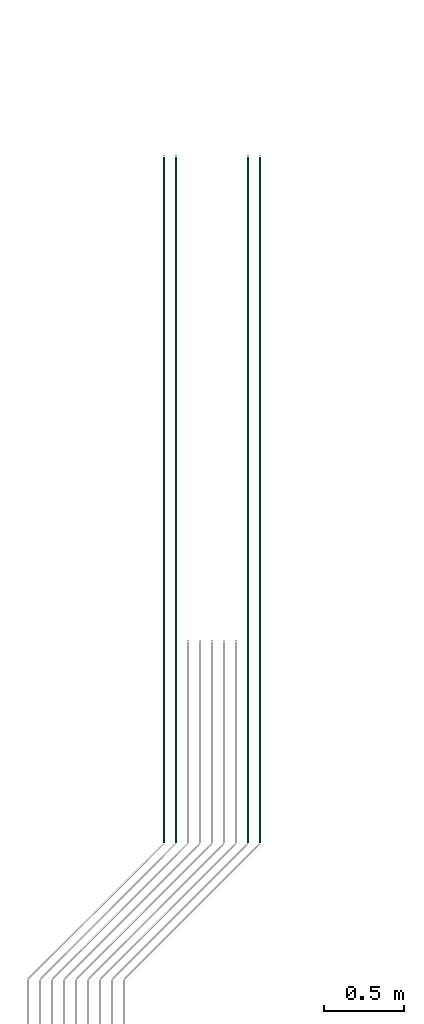
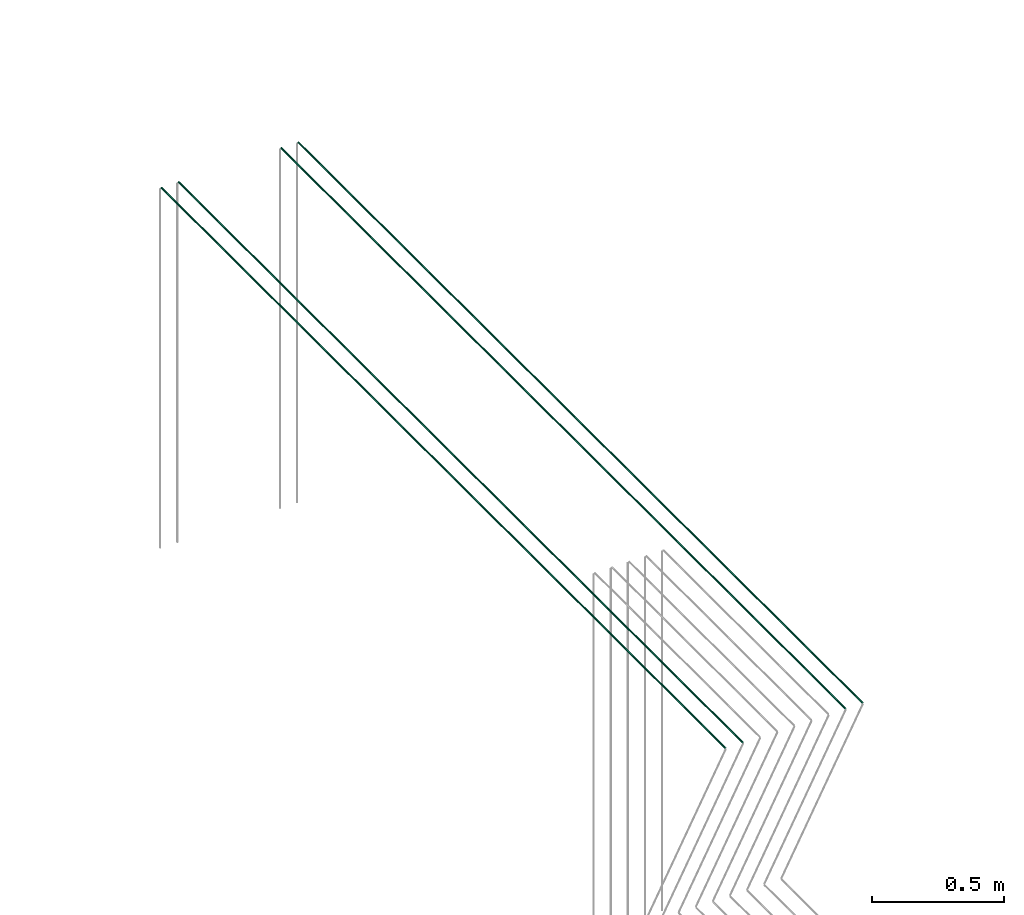
# One storey, part 13 of 89: 4 flow segments.
"""IFC2X3 building model written with IfcOpenShell, lengths in millimetres."""

import ifcopenshell
import ifcopenshell.guid

model = None  # the IFC model being written
_history = None  # IfcOwnerHistory: only IFC2X3 demands one
_inside = {}  # id of a spatial element -> (the spatial element, [elements in it])
_under = {}  # id of a project, library or spatial element -> (it, [spatial elements below it])
_declared = {}  # id of a project -> (the project, [libraries it declares])
_typed = {}  # id of a type object -> (the type object, [elements of that type])
_made_of = {}  # id of a material, layer set ... -> (it, [elements and type objects made of it])


def new_model(schema):
    """Start an empty IFC model of exactly this schema.

    Asked for "IFC4X3", IfcOpenShell would pick the latest addendum, in which some entities
    have other attributes; the version numbers below select the first issue.
    IFC2X3 requires an IfcOwnerHistory on every rooted entity: one is made here for all.
    """
    global model, _history
    if schema == "IFC4X3":
        model = ifcopenshell.file(schema_version=(4, 3, 0, 0))
    else:
        model = ifcopenshell.file(schema=schema)
    _inside.clear()
    _under.clear()
    _declared.clear()
    _typed.clear()
    _made_of.clear()
    _history = None
    if model.schema == "IFC2X3":
        org = make("IfcOrganization", Name="unknown")
        user = make(
            "IfcPersonAndOrganization",
            ThePerson=make("IfcPerson", FamilyName="unknown"),
            TheOrganization=org,
        )
        app = make(
            "IfcApplication",
            ApplicationDeveloper=org,
            Version="unknown",
            ApplicationFullName="unknown",
            ApplicationIdentifier="unknown",
        )
        _history = make(
            "IfcOwnerHistory",
            OwningUser=user,
            OwningApplication=app,
            ChangeAction="ADDED",
            CreationDate=0,
        )
    return model


def make(cls, **values):
    """One entity of the class cls with the attributes given. An attribute that is None is left unset."""
    return model.create_entity(
        cls, **{name: value for name, value in values.items() if value is not None}
    )


def entity(cls, *values):
    """Any entity or typed value of the class cls, its attributes in the order of the schema. None: left unset."""
    e = model.create_entity(cls)
    for i, value in enumerate(values):
        if value is not None:
            e[i] = value
    return e


def rooted(cls, **values):
    """An entity with a GlobalId (a new one), such as an element, a storey or a relation."""
    return make(cls, GlobalId=ifcopenshell.guid.new(), OwnerHistory=_history, **values)


def si_unit(unit_type, name, prefix=None):
    """IfcSIUnit, for example si_unit("LENGTHUNIT", "METRE", prefix="MILLI")."""
    return make("IfcSIUnit", UnitType=unit_type, Prefix=prefix, Name=name)


def converted_unit(unit_type, name, factor, base, dimensions=None, offset=None):
    """IfcConversionBasedUnit, such as the inch: factor (a typed value) times the base unit."""
    return make(
        "IfcConversionBasedUnit"
        if offset is None
        else "IfcConversionBasedUnitWithOffset",
        ConversionOffset=offset,
        Dimensions=None
        if dimensions is None
        else entity("IfcDimensionalExponents", *dimensions),
        UnitType=unit_type,
        Name=name,
        ConversionFactor=make(
            "IfcMeasureWithUnit", ValueComponent=factor, UnitComponent=base
        ),
    )


def derived_unit(unit_type, elements):
    """IfcDerivedUnit: a product of units, each with its exponent."""
    return make(
        "IfcDerivedUnit",
        Elements=[
            make("IfcDerivedUnitElement", Unit=unit, Exponent=power)
            for unit, power in elements
        ],
        UnitType=unit_type,
    )


def assignment(units):
    """IfcUnitAssignment: the units of a project."""
    return None if units is None else make("IfcUnitAssignment", Units=units)


def point(xyz):
    """IfcCartesianPoint."""
    return None if xyz is None else make("IfcCartesianPoint", Coordinates=xyz)


def direction(xyz):
    """IfcDirection."""
    return None if xyz is None else make("IfcDirection", DirectionRatios=xyz)


def frame(location, z_axis=None, x_axis=None):
    """IfcAxis2Placement3D, a coordinate frame: its origin and axes. An axis left out is left unset."""
    return make(
        "IfcAxis2Placement3D",
        Location=point(location),
        Axis=direction(z_axis),
        RefDirection=direction(x_axis),
    )


def frame_2d(location, x_axis=None):
    """IfcAxis2Placement2D, a coordinate frame in the plane: its origin and x axis."""
    return make(
        "IfcAxis2Placement2D", Location=point(location), RefDirection=direction(x_axis)
    )


def origin():
    """The frame at (0, 0, 0) with its axes left unset."""
    return frame((0.0, 0.0, 0.0))


def origin_2d_with_axis():
    """The frame at (0, 0) in the plane with the x axis (1, 0) written out."""
    return frame_2d((0.0, 0.0), x_axis=(1.0, 0.0))


def place(relative_to, where):
    """IfcLocalPlacement: puts the frame where relative to a parent placement (None: the world)."""
    return make(
        "IfcLocalPlacement", PlacementRelTo=relative_to, RelativePlacement=where
    )


def context(
    kind, dimensions, precision=None, world=None, true_north=None, identifier=None
):
    """IfcGeometricRepresentationContext, for example the 3D "Model" context."""
    return make(
        "IfcGeometricRepresentationContext",
        ContextIdentifier=identifier,
        ContextType=kind,
        CoordinateSpaceDimension=dimensions,
        Precision=precision,
        WorldCoordinateSystem=world,
        TrueNorth=true_north,
    )


def subcontext(parent, identifier, kind, view, scale=None):
    """IfcGeometricRepresentationSubContext, for example "Body" below "Model"."""
    return make(
        "IfcGeometricRepresentationSubContext",
        ContextIdentifier=identifier,
        ContextType=kind,
        ParentContext=parent,
        TargetScale=scale,
        TargetView=view,
    )


def project(units=None, contexts=None):
    """IfcProject with its units and contexts."""
    return rooted(
        "IfcProject",
        Name="project",
        RepresentationContexts=contexts,
        UnitsInContext=assignment(units),
    )


def spatial(cls, under=None, at=None, **own):
    """A site, building, storey or space (cls), placed at a placement, below another one or the project."""
    s = rooted(cls, ObjectPlacement=at, **own)
    if under is not None:
        _under.setdefault(under.id(), (under, []))[1].append(s)
    return s


def profile(cls, at=None, kind="AREA", **sizes):
    """A parametric profile (cls). Its sizes go by their IFC names, for example OverallWidth=200.0."""
    return make(cls, ProfileType=kind, Position=at, **sizes)


def circle(**sizes):
    """IfcCircleProfileDef."""
    return profile("IfcCircleProfileDef", **sizes)


def extrude(swept, where, along, depth):
    """IfcExtrudedAreaSolid: the profile swept, set in the frame where, extruded along a direction by depth."""
    return make(
        "IfcExtrudedAreaSolid",
        SweptArea=swept,
        Position=where,
        ExtrudedDirection=direction(along),
        Depth=depth,
    )


def shape(context_of_items, identifier, shape_type, items):
    """IfcShapeRepresentation: the items that make up one representation, for example the "Body"."""
    return make(
        "IfcShapeRepresentation",
        ContextOfItems=context_of_items,
        RepresentationIdentifier=identifier,
        RepresentationType=shape_type,
        Items=items,
    )


def made_of(thing, what):
    """Note that an element or type object is made of a material, layer set ...; save() writes the relation."""
    if what is not None:
        _made_of.setdefault(what.id(), (what, []))[1].append(thing)
    return thing


def type_object(cls, material=None, **own):
    """A type object (cls), such as IfcWallType, which elements share."""
    return made_of(rooted(cls, **own), material)


def element(
    cls,
    number,
    at=None,
    inside=None,
    cuts=None,
    type_object=None,
    material=None,
    context=None,
    identifier="Body",
    shape_type=None,
    held_by="IfcProductDefinitionShape",
    body=None,
    shapes=None,
    **own,
):
    """One element of the class cls, such as IfcWall. Its Tag is "e" and its number.

    at: its placement. inside: the storey or other place that contains it. cuts: it is an
    opening in that element (IfcRelVoidsElement). A single representation is given by context,
    identifier, shape_type and body (its items); several are given by shapes. held_by: the class
    of the entity that holds the representations. save() writes the other relations.
    """
    e = rooted(cls, Tag="e%d" % number, ObjectPlacement=at, **own)
    if body is not None:
        shapes = [shape(context, identifier, shape_type, body)]
    if shapes is not None:
        e.Representation = make(held_by, Representations=shapes)
    if inside is not None:
        _inside.setdefault(inside.id(), (inside, []))[1].append(e)
    if cuts is not None:
        rooted(
            "IfcRelVoidsElement", RelatingBuildingElement=cuts, RelatedOpeningElement=e
        )
    if type_object is not None:
        _typed.setdefault(type_object.id(), (type_object, []))[1].append(e)
    return made_of(e, material)


def aggregate(whole, parts):
    """IfcRelAggregates: a whole, such as a stair, and the parts it consists of."""
    return rooted("IfcRelAggregates", RelatingObject=whole, RelatedObjects=parts)


def save(model, path):
    """Write the relations noted so far, then the file.

    IfcRelAggregates (storeys below a building ...), IfcRelContainedInSpatialStructure (elements
    in a storey), IfcRelDefinesByType, IfcRelAssociatesMaterial and IfcRelDeclares: one each for
    every whole, place, type object, material and project.
    """
    for whole, parts in _under.values():
        aggregate(whole, parts)
    for where, things in _inside.values():
        rooted(
            "IfcRelContainedInSpatialStructure",
            RelatedElements=things,
            RelatingStructure=where,
        )
    for kind, things in _typed.values():
        rooted("IfcRelDefinesByType", RelatedObjects=things, RelatingType=kind)
    for what, things in _made_of.values():
        rooted("IfcRelAssociatesMaterial", RelatedObjects=things, RelatingMaterial=what)
    for by, libraries in _declared.values():
        rooted("IfcRelDeclares", RelatingContext=by, RelatedDefinitions=libraries)
    model.write(path)


model = new_model("IFC2X3")

# Units and contexts
model_context = context("Model", 3, precision=0.01, world=origin(), true_north=direction((6.12303176911189e-17, 1.0)))
body_context = subcontext(model_context, "Body", "Model", "MODEL_VIEW")
ifc_project = project(units=[si_unit("LENGTHUNIT", "METRE", prefix="MILLI"), si_unit("AREAUNIT", "SQUARE_METRE"), si_unit("VOLUMEUNIT", "CUBIC_METRE"), converted_unit("PLANEANGLEUNIT", "DEGREE", entity("IfcRatioMeasure", 0.0174532925199433), si_unit("PLANEANGLEUNIT", "RADIAN"), dimensions=[0, 0, 0, 0, 0, 0, 0]), si_unit("MASSUNIT", "GRAM", prefix="KILO"), derived_unit("MASSDENSITYUNIT", [(si_unit("MASSUNIT", "GRAM", prefix="KILO"), 1), (si_unit("LENGTHUNIT", "METRE"), -3)]), derived_unit("MOMENTOFINERTIAUNIT", [(si_unit("LENGTHUNIT", "METRE"), 4)]), si_unit("TIMEUNIT", "SECOND"), si_unit("FREQUENCYUNIT", "HERTZ"), si_unit("THERMODYNAMICTEMPERATUREUNIT", "DEGREE_CELSIUS"), derived_unit("THERMALTRANSMITTANCEUNIT", [(si_unit("MASSUNIT", "GRAM", prefix="KILO"), 1), (si_unit("THERMODYNAMICTEMPERATUREUNIT", "KELVIN"), -1), (si_unit("TIMEUNIT", "SECOND"), -3)]), derived_unit("VOLUMETRICFLOWRATEUNIT", [(si_unit("LENGTHUNIT", "METRE"), 3), (si_unit("TIMEUNIT", "SECOND"), -1)]), derived_unit("MASSFLOWRATEUNIT", [(si_unit("MASSUNIT", "GRAM", prefix="KILO"), 1), (si_unit("TIMEUNIT", "SECOND"), -1)]), derived_unit("ROTATIONALFREQUENCYUNIT", [(si_unit("TIMEUNIT", "SECOND"), -1)]), si_unit("ELECTRICCURRENTUNIT", "AMPERE"), si_unit("ELECTRICVOLTAGEUNIT", "VOLT"), si_unit("POWERUNIT", "WATT"), si_unit("FORCEUNIT", "NEWTON", prefix="KILO"), si_unit("ILLUMINANCEUNIT", "LUX"), si_unit("LUMINOUSFLUXUNIT", "LUMEN"), si_unit("LUMINOUSINTENSITYUNIT", "CANDELA"), derived_unit("USERDEFINED", [(si_unit("MASSUNIT", "GRAM", prefix="KILO"), -1), (si_unit("LENGTHUNIT", "METRE"), -2), (si_unit("TIMEUNIT", "SECOND"), 3), (si_unit("LUMINOUSFLUXUNIT", "LUMEN"), 1)]), derived_unit("LINEARVELOCITYUNIT", [(si_unit("LENGTHUNIT", "METRE"), 1), (si_unit("TIMEUNIT", "SECOND"), -1)]), si_unit("PRESSUREUNIT", "PASCAL"), derived_unit("USERDEFINED", [(si_unit("LENGTHUNIT", "METRE"), -2), (si_unit("MASSUNIT", "GRAM", prefix="KILO"), 1), (si_unit("TIMEUNIT", "SECOND"), -2)]), derived_unit("LINEARFORCEUNIT", [(si_unit("MASSUNIT", "GRAM", prefix="KILO"), 1), (si_unit("LENGTHUNIT", "METRE"), 1), (si_unit("TIMEUNIT", "SECOND"), -2), (si_unit("LENGTHUNIT", "METRE"), -1)]), derived_unit("PLANARFORCEUNIT", [(si_unit("MASSUNIT", "GRAM", prefix="KILO"), 1), (si_unit("LENGTHUNIT", "METRE"), 1), (si_unit("TIMEUNIT", "SECOND"), -2), (si_unit("LENGTHUNIT", "METRE"), -2)])], contexts=[model_context])

# Site, building, storey
site_placement = place(None, frame((0.0, -0.00077364408347762, 0.0)))
site = spatial("IfcSite", under=ifc_project, at=site_placement, CompositionType="ELEMENT")
building_placement = place(site_placement, origin())
building = spatial("IfcBuilding", under=site, at=building_placement, CompositionType="ELEMENT")
storey_placement = place(building_placement, frame((0.0, 0.0, 24000.0)))
storey = spatial("IfcBuildingStorey", under=building, at=storey_placement, CompositionType="ELEMENT", Elevation=24000.0)

# Flow segments
pipe_segment_type = type_object("IfcPipeSegmentType", PredefinedType="NOTDEFINED")
flow_segment_1_placement = place(storey_placement, frame((53835.5981151137, 4108.78711034957, 3069.40472776409)))
element("IfcFlowSegment", 1, at=flow_segment_1_placement, inside=storey, type_object=pipe_segment_type, context=body_context, shape_type="SweptSolid", body=[
    extrude(circle(Radius=4.0, at=origin_2d_with_axis()), frame((5.59527223591499, 0.0, 5.59527223591499), z_axis=(0.0, 1.0, 0.0), x_axis=(-1.0, 0.0, 0.0)), (0.0, 0.0, 1.0), 4281.20212097627),
])
flow_segment_2_placement = place(storey_placement, frame((53910.5981151137, 4107.27184210549, 3069.40472776409)))
element("IfcFlowSegment", 2, at=flow_segment_2_placement, inside=storey, type_object=pipe_segment_type, context=body_context, shape_type="SweptSolid", body=[
    extrude(circle(Radius=4.0, at=frame_2d((8.66293703438714e-12, 0.0), x_axis=(1.0, 0.0))), frame((5.59527223592365, 0.0, 5.59527223591499), z_axis=(0.0, 1.0, 0.0), x_axis=(-1.0, 0.0, 0.0)), (0.0, 0.0, 1.0), 4282.71738922034),
])
for number, where in (
    (3, (54360.5981151137, 4107.27184210549, 3069.40472776409)),
    (4, (54435.5981151137, 4107.27184210549, 3069.40472776409)),
):
    element("IfcFlowSegment", number, at=place(storey_placement, frame(where)), inside=storey, type_object=pipe_segment_type, context=body_context, shape_type="SweptSolid", body=[
        extrude(circle(Radius=4.0, at=frame_2d((8.66293703438714e-12, 0.0), x_axis=(1.0, 0.0))), frame((5.59527223591499, 0.0, 5.59527223591499), z_axis=(0.0, 1.0, 0.0), x_axis=(-1.0, 0.0, 0.0)), (0.0, 0.0, 1.0), 4282.71738922034),
    ])

save(model, "model.ifc")
